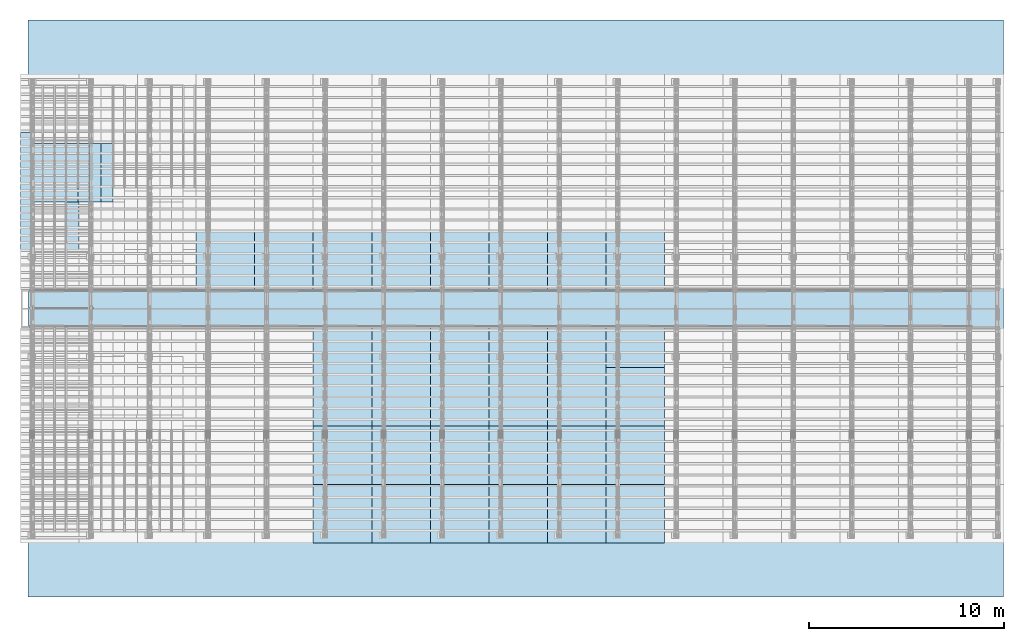
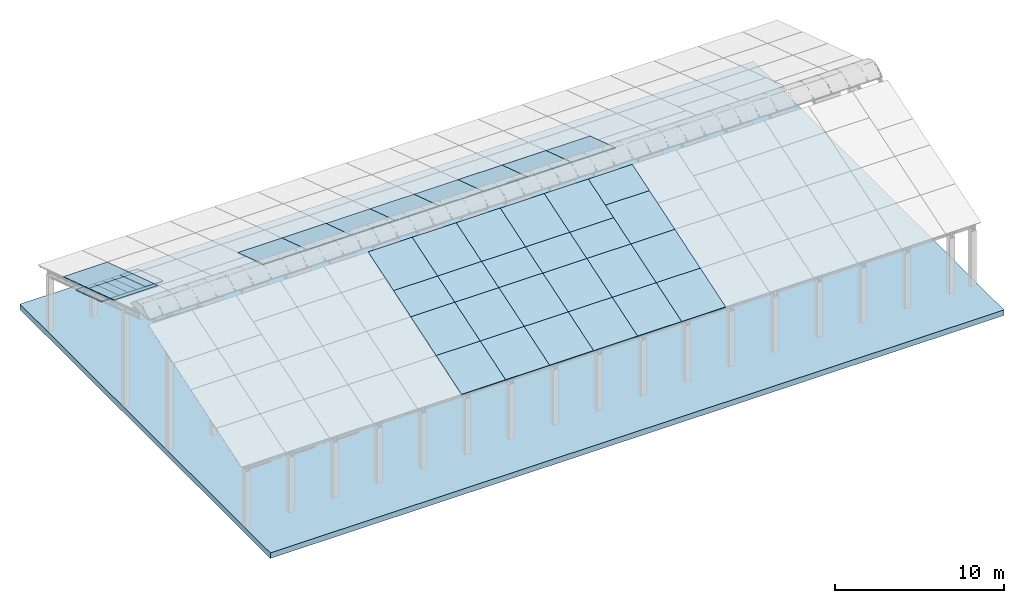
# One storey, part 7 of 385: 43 slabs, 42 elements without a shape of their own.
"""IFC2X3 building model written with IfcOpenShell, lengths in millimetres."""

from ifc_helpers import new_model, entity, si_unit, converted_unit, derived_unit, direction, frame, frame_2d, origin, place, context, subcontext, project, spatial, rectangle, extrude, material, layer, layer_set, type_object, element, aggregate, save


model = new_model("IFC2X3")

# Units and contexts
model_context = context("Model", 3, precision=0.01, world=origin(), true_north=direction((6.12303176911189e-17, 1.0)))
body_context = subcontext(model_context, "Body", "Model", "MODEL_VIEW")
ifc_project = project(units=[si_unit("LENGTHUNIT", "METRE", prefix="MILLI"), si_unit("AREAUNIT", "SQUARE_METRE"), si_unit("VOLUMEUNIT", "CUBIC_METRE"), converted_unit("PLANEANGLEUNIT", "DEGREE", entity("IfcRatioMeasure", 0.0174532925199433), si_unit("PLANEANGLEUNIT", "RADIAN"), dimensions=[0, 0, 0, 0, 0, 0, 0]), si_unit("MASSUNIT", "GRAM", prefix="KILO"), derived_unit("MASSDENSITYUNIT", [(si_unit("MASSUNIT", "GRAM", prefix="KILO"), 1), (si_unit("LENGTHUNIT", "METRE"), -3)]), si_unit("TIMEUNIT", "SECOND"), si_unit("FREQUENCYUNIT", "HERTZ"), si_unit("THERMODYNAMICTEMPERATUREUNIT", "DEGREE_CELSIUS"), derived_unit("THERMALTRANSMITTANCEUNIT", [(si_unit("MASSUNIT", "GRAM", prefix="KILO"), 1), (si_unit("THERMODYNAMICTEMPERATUREUNIT", "KELVIN"), -1), (si_unit("TIMEUNIT", "SECOND"), -3)]), derived_unit("VOLUMETRICFLOWRATEUNIT", [(si_unit("LENGTHUNIT", "METRE"), 3), (si_unit("TIMEUNIT", "SECOND"), -1)]), si_unit("ELECTRICCURRENTUNIT", "AMPERE"), si_unit("ELECTRICVOLTAGEUNIT", "VOLT"), si_unit("POWERUNIT", "WATT"), si_unit("FORCEUNIT", "NEWTON", prefix="KILO"), si_unit("ILLUMINANCEUNIT", "LUX"), si_unit("LUMINOUSFLUXUNIT", "LUMEN"), si_unit("LUMINOUSINTENSITYUNIT", "CANDELA"), derived_unit("USERDEFINED", [(si_unit("MASSUNIT", "GRAM", prefix="KILO"), -1), (si_unit("LENGTHUNIT", "METRE"), -2), (si_unit("TIMEUNIT", "SECOND"), 3), (si_unit("LUMINOUSFLUXUNIT", "LUMEN"), 1)]), derived_unit("LINEARVELOCITYUNIT", [(si_unit("LENGTHUNIT", "METRE"), 1), (si_unit("TIMEUNIT", "SECOND"), -1)]), si_unit("PRESSUREUNIT", "PASCAL"), derived_unit("USERDEFINED", [(si_unit("LENGTHUNIT", "METRE"), -2), (si_unit("MASSUNIT", "GRAM", prefix="KILO"), 1), (si_unit("TIMEUNIT", "SECOND"), -2)])], contexts=[model_context])

# Site, building, storey
site_placement = place(None, origin())
site = spatial("IfcSite", under=ifc_project, at=site_placement, CompositionType="ELEMENT")
building_placement = place(site_placement, origin())
building = spatial("IfcBuilding", under=site, at=building_placement, CompositionType="ELEMENT")
storey_placement = place(building_placement, origin())
storey = spatial("IfcBuildingStorey", under=building, at=storey_placement, Name="Default", CompositionType="ELEMENT", Elevation=0.0)

# Slab
ifc_material_1 = material(Name="IfcSurfaceStyle #136")
slab_type = type_object("IfcSlabType", Name="Floor 1", PredefinedType="FLOOR", material=ifc_material_1)
slab_1_placement = place(building_placement, origin())
element("IfcSlab", 1, at=slab_1_placement, inside=storey, type_object=slab_type, Name="Floor 1:Floor 1", ObjectType="Floor 1:Floor 1", PredefinedType="FLOOR", context=body_context, shape_type="SweptSolid", body=[
    extrude(rectangle(XDim=50000.0, YDim=29560.0, at=frame_2d((3.63797880709171e-12, 2.72848410531878e-12), x_axis=(1.0, 0.0))), frame((25055.7043482528, 14726.7615632183, -4400.0), z_axis=(0.0, 0.0, 1.0), x_axis=(-1.0, 0.0, 0.0)), (0.0, 0.0, 1.0), 399.999999999997),
])

# Roof, slab
roof_1_placement = place(storey_placement, frame((-325.490958783834, 20742.4435684862, 1569.65703643478)))
roof_1 = element("IfcRoof", 2, at=roof_1_placement, inside=storey, ShapeType="NOTDEFINED")
ifc_material_2 = material()
ifc_layer_1 = layer(ifc_material_2, 40.0)
ifc_layer_set_1 = layer_set([ifc_layer_1])
slab_2_placement = place(roof_1_placement, origin())
slab_2 = element("IfcSlab", 3, at=slab_2_placement, material=ifc_layer_set_1, PredefinedType="ROOF", context=body_context, shape_type="SweptSolid", body=[
    extrude(rectangle(XDim=3154.3866727148, YDim=2999.99999999999, at=frame_2d((-4.54747350886464e-13, 1.13686837721616e-13), x_axis=(0.0, 1.0))), frame((1500.0, 1500.0, 487.379544349359), z_axis=(0.0, 0.309016994374947, 0.951056516295154), x_axis=(1.0, 0.0, 0.0)), (0.0, -0.309016994374947, 0.951056516295154), 42.0584889695308),
])
aggregate(roof_1, [slab_2])

roof_2_placement = place(storey_placement, frame((-325.490958783839, 17742.4435684862, 2544.4161251335)))
roof_2 = element("IfcRoof", 4, at=roof_2_placement, inside=storey, ShapeType="NOTDEFINED")
slab_3_placement = place(roof_2_placement, origin())
slab_3 = element("IfcSlab", 5, at=slab_3_placement, material=ifc_layer_set_1, PredefinedType="ROOF", context=body_context, shape_type="SweptSolid", body=[
    extrude(rectangle(XDim=3154.3866727148, YDim=2999.99999999999, at=frame_2d((-1.02318153949454e-12, 1.13686837721616e-12), x_axis=(0.0, 1.0))), frame((1500.0, 1500.0, 487.379544349359), z_axis=(0.0, 0.309016994374947, 0.951056516295154), x_axis=(1.0, 0.0, 0.0)), (0.0, -0.309016994374947, 0.951056516295154), 42.0584889695308),
])
aggregate(roof_2, [slab_3])

roof_3_placement = place(building_placement, frame((210.0, 20167.6676853402, 788.261817465712)))
roof_3 = element("IfcRoof", 6, at=roof_3_placement, inside=storey, ShapeType="NOTDEFINED")
ifc_material_3 = material(Name="NLRS_n7_isolatie MegaPlus_Kingspan")
ifc_layer_2 = layer(ifc_material_3, 60.0)
ifc_layer_set_2 = layer_set([ifc_layer_2])
slab_4_placement = place(roof_3_placement, origin())
slab_4 = element("IfcSlab", 7, at=slab_4_placement, material=ifc_layer_set_2, PredefinedType="ROOF", context=body_context, shape_type="SweptSolid", body=[
    extrude(rectangle(XDim=600.0, YDim=3154.38667271481, at=frame_2d((0.0, 0.0), x_axis=(-1.0, 0.0))), frame((300.0, 1500.0, 487.379544349361), z_axis=(0.0, 0.309016994374947, 0.951056516295154), x_axis=(1.0, 0.0, 0.0)), (0.0, -0.309016994374947, 0.951056516295154), 63.087733454296),
])
aggregate(roof_3, [slab_4])

roof_4_placement = place(storey_placement, frame((810.0, 20167.6676853402, 788.261817465712)))
roof_4 = element("IfcRoof", 8, at=roof_4_placement, inside=storey, ShapeType="NOTDEFINED")
slab_5_placement = place(roof_4_placement, origin())
slab_5 = element("IfcSlab", 9, at=slab_5_placement, material=ifc_layer_set_2, PredefinedType="ROOF", context=body_context, shape_type="SweptSolid", body=[
    extrude(rectangle(XDim=600.0, YDim=3154.38667271481, at=frame_2d((0.0, 0.0), x_axis=(-1.0, 0.0))), frame((300.0, 1500.0, 487.379544349361), z_axis=(0.0, 0.309016994374947, 0.951056516295154), x_axis=(1.0, 0.0, 0.0)), (0.0, -0.309016994374947, 0.951056516295154), 63.087733454296),
])
aggregate(roof_4, [slab_5])

roof_5_placement = place(storey_placement, frame((1410.0, 20167.6676853402, 788.261817465712)))
roof_5 = element("IfcRoof", 10, at=roof_5_placement, inside=storey, ShapeType="NOTDEFINED")
slab_6_placement = place(roof_5_placement, origin())
slab_6 = element("IfcSlab", 11, at=slab_6_placement, material=ifc_layer_set_2, PredefinedType="ROOF", context=body_context, shape_type="SweptSolid", body=[
    extrude(rectangle(XDim=600.0, YDim=3154.38667271481, at=frame_2d((0.0, 0.0), x_axis=(-1.0, 0.0))), frame((300.0, 1500.0, 487.379544349361), z_axis=(0.0, 0.309016994374947, 0.951056516295154), x_axis=(1.0, 0.0, 0.0)), (0.0, -0.309016994374947, 0.951056516295154), 63.087733454296),
])
aggregate(roof_5, [slab_6])

roof_6_placement = place(storey_placement, frame((2010.0, 20167.6676853402, 788.261817465712)))
roof_6 = element("IfcRoof", 12, at=roof_6_placement, inside=storey, ShapeType="NOTDEFINED")
slab_7_placement = place(roof_6_placement, origin())
slab_7 = element("IfcSlab", 13, at=slab_7_placement, material=ifc_layer_set_2, PredefinedType="ROOF", context=body_context, shape_type="SweptSolid", body=[
    extrude(rectangle(XDim=600.0, YDim=3154.38667271481, at=frame_2d((0.0, 0.0), x_axis=(-1.0, 0.0))), frame((300.0, 1500.0, 487.379544349361), z_axis=(0.0, 0.309016994374947, 0.951056516295154), x_axis=(1.0, 0.0, 0.0)), (0.0, -0.309016994374947, 0.951056516295154), 63.087733454296),
])
aggregate(roof_6, [slab_7])

roof_7_placement = place(storey_placement, frame((2610.0, 20167.6676853402, 788.261817465712)))
roof_7 = element("IfcRoof", 14, at=roof_7_placement, inside=storey, ShapeType="NOTDEFINED")
slab_8_placement = place(roof_7_placement, origin())
slab_8 = element("IfcSlab", 15, at=slab_8_placement, material=ifc_layer_set_2, PredefinedType="ROOF", context=body_context, shape_type="SweptSolid", body=[
    extrude(rectangle(XDim=600.0, YDim=3154.38667271481, at=frame_2d((0.0, 0.0), x_axis=(-1.0, 0.0))), frame((300.0, 1500.0, 487.379544349361), z_axis=(0.0, 0.309016994374947, 0.951056516295154), x_axis=(1.0, 0.0, 0.0)), (0.0, -0.309016994374947, 0.951056516295154), 63.087733454296),
])
aggregate(roof_7, [slab_8])

roof_8_placement = place(storey_placement, frame((3210.0, 20167.6676853402, 788.261817465712)))
roof_8 = element("IfcRoof", 16, at=roof_8_placement, inside=storey, ShapeType="NOTDEFINED")
slab_9_placement = place(roof_8_placement, origin())
slab_9 = element("IfcSlab", 17, at=slab_9_placement, material=ifc_layer_set_2, PredefinedType="ROOF", context=body_context, shape_type="SweptSolid", body=[
    extrude(rectangle(XDim=600.0, YDim=3154.38667271481, at=frame_2d((0.0, 0.0), x_axis=(-1.0, 0.0))), frame((300.0, 1500.0, 487.379544349361), z_axis=(0.0, 0.309016994374947, 0.951056516295154), x_axis=(1.0, 0.0, 0.0)), (0.0, -0.309016994374947, 0.951056516295154), 63.087733454296),
])
aggregate(roof_8, [slab_9])

roof_9_placement = place(storey_placement, frame((3810.0, 20167.6676853402, 788.261817465712)))
roof_9 = element("IfcRoof", 18, at=roof_9_placement, inside=storey, ShapeType="NOTDEFINED")
slab_10_placement = place(roof_9_placement, origin())
slab_10 = element("IfcSlab", 19, at=slab_10_placement, material=ifc_layer_set_2, PredefinedType="ROOF", context=body_context, shape_type="SweptSolid", body=[
    extrude(rectangle(XDim=600.0, YDim=3154.38667271481, at=frame_2d((0.0, 0.0), x_axis=(-1.0, 0.0))), frame((300.0, 1500.0, 487.379544349361), z_axis=(0.0, 0.309016994374947, 0.951056516295154), x_axis=(1.0, 0.0, 0.0)), (0.0, -0.309016994374947, 0.951056516295154), 63.087733454296),
])
aggregate(roof_9, [slab_10])

roof_10_placement = place(storey_placement, frame((3210.0, 20167.6676853402, 788.261817465712)))
roof_10 = element("IfcRoof", 20, at=roof_10_placement, inside=storey, ShapeType="NOTDEFINED")
slab_11_placement = place(roof_10_placement, origin())
slab_11 = element("IfcSlab", 21, at=slab_11_placement, material=ifc_layer_set_2, PredefinedType="ROOF", context=body_context, shape_type="SweptSolid", body=[
    extrude(rectangle(XDim=600.0, YDim=3154.38667271481, at=frame_2d((0.0, 0.0), x_axis=(-1.0, 0.0))), frame((300.0, 1500.0, 487.379544349361), z_axis=(0.0, 0.309016994374947, 0.951056516295154), x_axis=(1.0, 0.0, 0.0)), (0.0, -0.309016994374947, 0.951056516295154), 63.087733454296),
])
aggregate(roof_10, [slab_11])

roof_11_placement = place(storey_placement, frame((8674.50904121613, 15713.9166481203, 3203.52447589904)))
roof_11 = element("IfcRoof", 22, at=roof_11_placement, inside=storey, ShapeType="NOTDEFINED")
slab_12_placement = place(roof_11_placement, origin())
slab_12 = element("IfcSlab", 23, at=slab_12_placement, material=ifc_layer_set_1, PredefinedType="ROOF", context=body_context, shape_type="SweptSolid", body=[
    extrude(rectangle(XDim=3154.3866727148, YDim=2999.99999999999, at=frame_2d((5.6843418860808e-13, 1.13686837721616e-12), x_axis=(0.0, 1.0))), frame((1500.0, 1500.0, 487.379544349359), z_axis=(0.0, 0.309016994374947, 0.951056516295154), x_axis=(1.0, 0.0, 0.0)), (0.0, -0.309016994374947, 0.951056516295154), 42.0584889695308),
])
aggregate(roof_11, [slab_12])

roof_12_placement = place(storey_placement, frame((11674.5090412161, 15713.9166481203, 3203.52447589904)))
roof_12 = element("IfcRoof", 24, at=roof_12_placement, inside=storey, ShapeType="NOTDEFINED")
slab_13_placement = place(roof_12_placement, origin())
slab_13 = element("IfcSlab", 25, at=slab_13_placement, material=ifc_layer_set_1, PredefinedType="ROOF", context=body_context, shape_type="SweptSolid", body=[
    extrude(rectangle(XDim=3154.3866727148, YDim=2999.99999999999, at=frame_2d((0.0, 1.13686837721616e-12), x_axis=(0.0, 1.0))), frame((1500.0, 1500.0, 487.379544349359), z_axis=(0.0, 0.309016994374947, 0.951056516295154), x_axis=(1.0, 0.0, 0.0)), (0.0, -0.309016994374947, 0.951056516295154), 42.0584889695308),
])
aggregate(roof_12, [slab_13])

roof_13_placement = place(storey_placement, frame((14674.5090412161, 2697.55668997139, 594.897947736069)))
roof_13 = element("IfcRoof", 26, at=roof_13_placement, inside=storey, ShapeType="NOTDEFINED")
slab_14_placement = place(roof_13_placement, origin())
slab_14 = element("IfcSlab", 27, at=slab_14_placement, material=ifc_layer_set_1, PredefinedType="ROOF", context=body_context, shape_type="SweptSolid", body=[
    extrude(rectangle(XDim=3154.3866727148, YDim=2999.99999999999, at=frame_2d((0.0, 5.6843418860808e-13), x_axis=(0.0, -1.0))), frame((1500.0, 1500.0, 487.379544349359), z_axis=(0.0, -0.309016994374947, 0.951056516295154), x_axis=(1.0, 0.0, 0.0)), (0.0, 0.309016994374947, 0.951056516295154), 42.0584889695306),
])
aggregate(roof_13, [slab_14])

roof_14_placement = place(storey_placement, frame((14674.5090412161, 5697.5566899714, 1569.65703643478)))
roof_14 = element("IfcRoof", 28, at=roof_14_placement, inside=storey, ShapeType="NOTDEFINED")
slab_15_placement = place(roof_14_placement, origin())
slab_15 = element("IfcSlab", 29, at=slab_15_placement, material=ifc_layer_set_1, PredefinedType="ROOF", context=body_context, shape_type="SweptSolid", body=[
    extrude(rectangle(XDim=3154.3866727148, YDim=2999.99999999999, at=frame_2d((0.0, 6.82121026329696e-13), x_axis=(0.0, -1.0))), frame((1500.0, 1500.0, 487.379544349359), z_axis=(0.0, -0.309016994374947, 0.951056516295154), x_axis=(1.0, 0.0, 0.0)), (0.0, 0.309016994374947, 0.951056516295154), 42.0584889695306),
])
aggregate(roof_14, [slab_15])

roof_15_placement = place(storey_placement, frame((14674.5090412161, 8697.5566899714, 2544.4161251335)))
roof_15 = element("IfcRoof", 30, at=roof_15_placement, inside=storey, ShapeType="NOTDEFINED")
slab_16_placement = place(roof_15_placement, origin())
slab_16 = element("IfcSlab", 31, at=slab_16_placement, material=ifc_layer_set_1, PredefinedType="ROOF", context=body_context, shape_type="SweptSolid", body=[
    extrude(rectangle(XDim=3154.38667271481, YDim=2999.99999999999, at=frame_2d((0.0, -5.6843418860808e-13), x_axis=(0.0, -1.0))), frame((1500.0, 1500.0, 487.379544349359), z_axis=(0.0, -0.309016994374947, 0.951056516295154), x_axis=(1.0, 0.0, 0.0)), (0.0, 0.309016994374947, 0.951056516295154), 42.0584889695308),
])
aggregate(roof_15, [slab_16])

roof_16_placement = place(storey_placement, frame((14674.5090412161, 15713.9166481203, 3203.52447589904)))
roof_16 = element("IfcRoof", 32, at=roof_16_placement, inside=storey, ShapeType="NOTDEFINED")
slab_17_placement = place(roof_16_placement, origin())
slab_17 = element("IfcSlab", 33, at=slab_17_placement, material=ifc_layer_set_1, PredefinedType="ROOF", context=body_context, shape_type="SweptSolid", body=[
    extrude(rectangle(XDim=3154.3866727148, YDim=2999.99999999999, at=frame_2d((0.0, 1.13686837721616e-12), x_axis=(0.0, 1.0))), frame((1500.0, 1500.0, 487.379544349359), z_axis=(0.0, 0.309016994374947, 0.951056516295154), x_axis=(1.0, 0.0, 0.0)), (0.0, -0.309016994374947, 0.951056516295154), 42.0584889695308),
])
aggregate(roof_16, [slab_17])

roof_17_placement = place(storey_placement, frame((14674.5090412161, 10724.9959924011, 3203.1710874096)))
roof_17 = element("IfcRoof", 34, at=roof_17_placement, inside=storey, ShapeType="NOTDEFINED")
slab_18_placement = place(roof_17_placement, origin())
slab_18 = element("IfcSlab", 35, at=slab_18_placement, material=ifc_layer_set_1, PredefinedType="ROOF", context=body_context, shape_type="SweptSolid", body=[
    extrude(rectangle(XDim=3154.3866727148, YDim=2999.99999999999, at=frame_2d((0.0, 0.0), x_axis=(0.0, -1.0))), frame((1500.0, 1500.0, 487.379544349359), z_axis=(0.0, -0.309016994374947, 0.951056516295154), x_axis=(1.0, 0.0, 0.0)), (0.0, 0.309016994374947, 0.951056516295154), 42.0584889695308),
])
aggregate(roof_17, [slab_18])

roof_18_placement = place(storey_placement, frame((17674.5090412161, 2697.55668997138, 594.897947736069)))
roof_18 = element("IfcRoof", 36, at=roof_18_placement, inside=storey, ShapeType="NOTDEFINED")
slab_19_placement = place(roof_18_placement, origin())
slab_19 = element("IfcSlab", 37, at=slab_19_placement, material=ifc_layer_set_1, PredefinedType="ROOF", context=body_context, shape_type="SweptSolid", body=[
    extrude(rectangle(XDim=3154.3866727148, YDim=2999.99999999999, at=frame_2d((0.0, 0.0), x_axis=(0.0, -1.0))), frame((1500.0, 1500.0, 487.379544349359), z_axis=(0.0, -0.309016994374947, 0.951056516295154), x_axis=(1.0, 0.0, 0.0)), (0.0, 0.309016994374947, 0.951056516295154), 42.0584889695306),
])
aggregate(roof_18, [slab_19])

roof_19_placement = place(storey_placement, frame((17674.5090412161, 5697.55668997139, 1569.65703643478)))
roof_19 = element("IfcRoof", 38, at=roof_19_placement, inside=storey, ShapeType="NOTDEFINED")
slab_20_placement = place(roof_19_placement, origin())
slab_20 = element("IfcSlab", 39, at=slab_20_placement, material=ifc_layer_set_1, PredefinedType="ROOF", context=body_context, shape_type="SweptSolid", body=[
    extrude(rectangle(XDim=3154.3866727148, YDim=2999.99999999999, at=frame_2d((0.0, 1.13686837721616e-13), x_axis=(0.0, -1.0))), frame((1500.0, 1500.0, 487.379544349359), z_axis=(0.0, -0.309016994374947, 0.951056516295154), x_axis=(1.0, 0.0, 0.0)), (0.0, 0.309016994374947, 0.951056516295154), 42.0584889695306),
])
aggregate(roof_19, [slab_20])

roof_20_placement = place(storey_placement, frame((17674.5090412161, 8697.5566899714, 2544.4161251335)))
roof_20 = element("IfcRoof", 40, at=roof_20_placement, inside=storey, ShapeType="NOTDEFINED")
slab_21_placement = place(roof_20_placement, origin())
slab_21 = element("IfcSlab", 41, at=slab_21_placement, material=ifc_layer_set_1, PredefinedType="ROOF", context=body_context, shape_type="SweptSolid", body=[
    extrude(rectangle(XDim=3154.38667271481, YDim=2999.99999999999, at=frame_2d((0.0, -1.25055521493778e-12), x_axis=(0.0, -1.0))), frame((1500.0, 1500.0, 487.37954434936), z_axis=(0.0, -0.309016994374947, 0.951056516295154), x_axis=(1.0, 0.0, 0.0)), (0.0, 0.309016994374947, 0.951056516295154), 42.0584889695303),
])
aggregate(roof_20, [slab_21])

roof_21_placement = place(storey_placement, frame((17674.5090412161, 15713.9166481203, 3203.52447589904)))
roof_21 = element("IfcRoof", 42, at=roof_21_placement, inside=storey, ShapeType="NOTDEFINED")
slab_22_placement = place(roof_21_placement, origin())
slab_22 = element("IfcSlab", 43, at=slab_22_placement, material=ifc_layer_set_1, PredefinedType="ROOF", context=body_context, shape_type="SweptSolid", body=[
    extrude(rectangle(XDim=3154.3866727148, YDim=2999.99999999999, at=frame_2d((0.0, 1.13686837721616e-12), x_axis=(0.0, 1.0))), frame((1500.0, 1500.0, 487.379544349359), z_axis=(0.0, 0.309016994374947, 0.951056516295154), x_axis=(1.0, 0.0, 0.0)), (0.0, -0.309016994374947, 0.951056516295154), 42.0584889695308),
])
aggregate(roof_21, [slab_22])

roof_22_placement = place(storey_placement, frame((17674.5090412161, 10724.9959924011, 3203.1710874096)))
roof_22 = element("IfcRoof", 44, at=roof_22_placement, inside=storey, ShapeType="NOTDEFINED")
slab_23_placement = place(roof_22_placement, origin())
slab_23 = element("IfcSlab", 45, at=slab_23_placement, material=ifc_layer_set_1, PredefinedType="ROOF", context=body_context, shape_type="SweptSolid", body=[
    extrude(rectangle(XDim=3154.3866727148, YDim=2999.99999999999, at=frame_2d((0.0, 0.0), x_axis=(0.0, -1.0))), frame((1500.0, 1500.0, 487.379544349359), z_axis=(0.0, -0.309016994374947, 0.951056516295154), x_axis=(1.0, 0.0, 0.0)), (0.0, 0.309016994374947, 0.951056516295154), 42.0584889695308),
])
aggregate(roof_22, [slab_23])

roof_23_placement = place(storey_placement, frame((20674.5090412161, 2697.55668997137, 594.897947736069)))
roof_23 = element("IfcRoof", 46, at=roof_23_placement, inside=storey, ShapeType="NOTDEFINED")
slab_24_placement = place(roof_23_placement, origin())
slab_24 = element("IfcSlab", 47, at=slab_24_placement, material=ifc_layer_set_1, PredefinedType="ROOF", context=body_context, shape_type="SweptSolid", body=[
    extrude(rectangle(XDim=3154.3866727148, YDim=2999.99999999999, at=frame_2d((0.0, 5.6843418860808e-13), x_axis=(0.0, -1.0))), frame((1500.0, 1500.0, 487.379544349359), z_axis=(0.0, -0.309016994374947, 0.951056516295154), x_axis=(1.0, 0.0, 0.0)), (0.0, 0.309016994374947, 0.951056516295154), 42.0584889695306),
])
aggregate(roof_23, [slab_24])

roof_24_placement = place(storey_placement, frame((20674.5090412161, 5697.55668997138, 1569.65703643478)))
roof_24 = element("IfcRoof", 48, at=roof_24_placement, inside=storey, ShapeType="NOTDEFINED")
slab_25_placement = place(roof_24_placement, origin())
slab_25 = element("IfcSlab", 49, at=slab_25_placement, material=ifc_layer_set_1, PredefinedType="ROOF", context=body_context, shape_type="SweptSolid", body=[
    extrude(rectangle(XDim=3154.3866727148, YDim=2999.99999999999, at=frame_2d((0.0, 6.82121026329696e-13), x_axis=(0.0, -1.0))), frame((1500.0, 1500.0, 487.379544349359), z_axis=(0.0, -0.309016994374947, 0.951056516295154), x_axis=(1.0, 0.0, 0.0)), (0.0, 0.309016994374947, 0.951056516295154), 42.0584889695306),
])
aggregate(roof_24, [slab_25])

roof_25_placement = place(storey_placement, frame((20674.5090412161, 8697.55668997138, 2544.4161251335)))
roof_25 = element("IfcRoof", 50, at=roof_25_placement, inside=storey, ShapeType="NOTDEFINED")
slab_26_placement = place(roof_25_placement, origin())
slab_26 = element("IfcSlab", 51, at=slab_26_placement, material=ifc_layer_set_1, PredefinedType="ROOF", context=body_context, shape_type="SweptSolid", body=[
    extrude(rectangle(XDim=3154.38667271481, YDim=2999.99999999999, at=frame_2d((0.0, 6.82121026329696e-13), x_axis=(0.0, -1.0))), frame((1500.0, 1500.0, 487.37954434936), z_axis=(0.0, -0.309016994374947, 0.951056516295154), x_axis=(1.0, 0.0, 0.0)), (0.0, 0.309016994374947, 0.951056516295154), 42.0584889695308),
])
aggregate(roof_25, [slab_26])

roof_26_placement = place(storey_placement, frame((20674.5090412161, 15713.9166481203, 3203.52447589904)))
roof_26 = element("IfcRoof", 52, at=roof_26_placement, inside=storey, ShapeType="NOTDEFINED")
slab_27_placement = place(roof_26_placement, origin())
slab_27 = element("IfcSlab", 53, at=slab_27_placement, material=ifc_layer_set_1, PredefinedType="ROOF", context=body_context, shape_type="SweptSolid", body=[
    extrude(rectangle(XDim=3154.3866727148, YDim=2999.99999999999, at=frame_2d((0.0, 1.13686837721616e-12), x_axis=(0.0, 1.0))), frame((1500.0, 1500.0, 487.379544349359), z_axis=(0.0, 0.309016994374947, 0.951056516295154), x_axis=(1.0, 0.0, 0.0)), (0.0, -0.309016994374947, 0.951056516295154), 42.0584889695308),
])
aggregate(roof_26, [slab_27])

roof_27_placement = place(storey_placement, frame((20674.5090412161, 10724.995992401, 3203.1710874096)))
roof_27 = element("IfcRoof", 54, at=roof_27_placement, inside=storey, ShapeType="NOTDEFINED")
slab_28_placement = place(roof_27_placement, origin())
slab_28 = element("IfcSlab", 55, at=slab_28_placement, material=ifc_layer_set_1, PredefinedType="ROOF", context=body_context, shape_type="SweptSolid", body=[
    extrude(rectangle(XDim=3154.3866727148, YDim=2999.99999999999, at=frame_2d((0.0, 0.0), x_axis=(0.0, -1.0))), frame((1500.0, 1500.0, 487.379544349359), z_axis=(0.0, -0.309016994374947, 0.951056516295154), x_axis=(1.0, 0.0, 0.0)), (0.0, 0.309016994374947, 0.951056516295154), 42.0584889695308),
])
aggregate(roof_27, [slab_28])

roof_28_placement = place(storey_placement, frame((23674.5090412161, 2697.55668997136, 594.897947736069)))
roof_28 = element("IfcRoof", 56, at=roof_28_placement, inside=storey, ShapeType="NOTDEFINED")
slab_29_placement = place(roof_28_placement, origin())
slab_29 = element("IfcSlab", 57, at=slab_29_placement, material=ifc_layer_set_1, PredefinedType="ROOF", context=body_context, shape_type="SweptSolid", body=[
    extrude(rectangle(XDim=3154.3866727148, YDim=2999.99999999999, at=frame_2d((0.0, 0.0), x_axis=(0.0, -1.0))), frame((1500.0, 1500.0, 487.379544349359), z_axis=(0.0, -0.309016994374947, 0.951056516295154), x_axis=(1.0, 0.0, 0.0)), (0.0, 0.309016994374947, 0.951056516295154), 42.0584889695306),
])
aggregate(roof_28, [slab_29])

roof_29_placement = place(storey_placement, frame((23674.5090412161, 5697.55668997137, 1569.65703643478)))
roof_29 = element("IfcRoof", 58, at=roof_29_placement, inside=storey, ShapeType="NOTDEFINED")
slab_30_placement = place(roof_29_placement, origin())
slab_30 = element("IfcSlab", 59, at=slab_30_placement, material=ifc_layer_set_1, PredefinedType="ROOF", context=body_context, shape_type="SweptSolid", body=[
    extrude(rectangle(XDim=3154.3866727148, YDim=2999.99999999999, at=frame_2d((0.0, 1.13686837721616e-13), x_axis=(0.0, -1.0))), frame((1500.0, 1500.0, 487.379544349359), z_axis=(0.0, -0.309016994374947, 0.951056516295154), x_axis=(1.0, 0.0, 0.0)), (0.0, 0.309016994374947, 0.951056516295154), 42.0584889695306),
])
aggregate(roof_29, [slab_30])

roof_30_placement = place(storey_placement, frame((23674.5090412161, 8697.55668997138, 2544.4161251335)))
roof_30 = element("IfcRoof", 60, at=roof_30_placement, inside=storey, ShapeType="NOTDEFINED")
slab_31_placement = place(roof_30_placement, origin())
slab_31 = element("IfcSlab", 61, at=slab_31_placement, material=ifc_layer_set_1, PredefinedType="ROOF", context=body_context, shape_type="SweptSolid", body=[
    extrude(rectangle(XDim=3154.38667271481, YDim=2999.99999999999, at=frame_2d((0.0, 0.0), x_axis=(0.0, -1.0))), frame((1500.0, 1500.0, 487.37954434936), z_axis=(0.0, -0.309016994374947, 0.951056516295154), x_axis=(1.0, 0.0, 0.0)), (0.0, 0.309016994374947, 0.951056516295154), 42.0584889695308),
])
aggregate(roof_30, [slab_31])

roof_31_placement = place(storey_placement, frame((23674.5090412161, 15713.9166481202, 3203.52447589904)))
roof_31 = element("IfcRoof", 62, at=roof_31_placement, inside=storey, ShapeType="NOTDEFINED")
slab_32_placement = place(roof_31_placement, origin())
slab_32 = element("IfcSlab", 63, at=slab_32_placement, material=ifc_layer_set_1, PredefinedType="ROOF", context=body_context, shape_type="SweptSolid", body=[
    extrude(rectangle(XDim=3154.3866727148, YDim=2999.99999999999, at=frame_2d((0.0, 1.13686837721616e-12), x_axis=(0.0, 1.0))), frame((1500.0, 1500.0, 487.379544349359), z_axis=(0.0, 0.309016994374947, 0.951056516295154), x_axis=(1.0, 0.0, 0.0)), (0.0, -0.309016994374947, 0.951056516295154), 42.0584889695308),
])
aggregate(roof_31, [slab_32])

roof_32_placement = place(storey_placement, frame((23674.5090412161, 10724.995992401, 3203.1710874096)))
roof_32 = element("IfcRoof", 64, at=roof_32_placement, inside=storey, ShapeType="NOTDEFINED")
slab_33_placement = place(roof_32_placement, origin())
slab_33 = element("IfcSlab", 65, at=slab_33_placement, material=ifc_layer_set_1, PredefinedType="ROOF", context=body_context, shape_type="SweptSolid", body=[
    extrude(rectangle(XDim=3154.3866727148, YDim=2999.99999999999, at=frame_2d((0.0, 0.0), x_axis=(0.0, -1.0))), frame((1500.0, 1500.0, 487.379544349359), z_axis=(0.0, -0.309016994374947, 0.951056516295154), x_axis=(1.0, 0.0, 0.0)), (0.0, 0.309016994374947, 0.951056516295154), 42.0584889695308),
])
aggregate(roof_32, [slab_33])

roof_33_placement = place(storey_placement, frame((26674.5090412161, 2697.55668997135, 594.897947736069)))
roof_33 = element("IfcRoof", 66, at=roof_33_placement, inside=storey, ShapeType="NOTDEFINED")
slab_34_placement = place(roof_33_placement, origin())
slab_34 = element("IfcSlab", 67, at=slab_34_placement, material=ifc_layer_set_1, PredefinedType="ROOF", context=body_context, shape_type="SweptSolid", body=[
    extrude(rectangle(XDim=3154.3866727148, YDim=2999.99999999999, at=frame_2d((0.0, 5.6843418860808e-13), x_axis=(0.0, -1.0))), frame((1500.0, 1500.0, 487.379544349359), z_axis=(0.0, -0.309016994374947, 0.951056516295154), x_axis=(1.0, 0.0, 0.0)), (0.0, 0.309016994374947, 0.951056516295154), 42.0584889695306),
])
aggregate(roof_33, [slab_34])

roof_34_placement = place(storey_placement, frame((26674.5090412161, 5697.55668997136, 1569.65703643478)))
roof_34 = element("IfcRoof", 68, at=roof_34_placement, inside=storey, ShapeType="NOTDEFINED")
slab_35_placement = place(roof_34_placement, origin())
slab_35 = element("IfcSlab", 69, at=slab_35_placement, material=ifc_layer_set_1, PredefinedType="ROOF", context=body_context, shape_type="SweptSolid", body=[
    extrude(rectangle(XDim=3154.3866727148, YDim=2999.99999999999, at=frame_2d((0.0, 6.82121026329696e-13), x_axis=(0.0, -1.0))), frame((1500.0, 1500.0, 487.379544349359), z_axis=(0.0, -0.309016994374947, 0.951056516295154), x_axis=(1.0, 0.0, 0.0)), (0.0, 0.309016994374947, 0.951056516295154), 42.0584889695306),
])
aggregate(roof_34, [slab_35])

roof_35_placement = place(storey_placement, frame((26674.5090412161, 8697.55668997136, 2544.4161251335)))
roof_35 = element("IfcRoof", 70, at=roof_35_placement, inside=storey, ShapeType="NOTDEFINED")
slab_36_placement = place(roof_35_placement, origin())
slab_36 = element("IfcSlab", 71, at=slab_36_placement, material=ifc_layer_set_1, PredefinedType="ROOF", context=body_context, shape_type="SweptSolid", body=[
    extrude(rectangle(XDim=3154.38667271481, YDim=2999.99999999999, at=frame_2d((0.0, -5.6843418860808e-13), x_axis=(0.0, -1.0))), frame((1500.0, 1500.0, 487.37954434936), z_axis=(0.0, -0.309016994374947, 0.951056516295154), x_axis=(1.0, 0.0, 0.0)), (0.0, 0.309016994374947, 0.951056516295154), 42.0584889695308),
])
aggregate(roof_35, [slab_36])

roof_36_placement = place(storey_placement, frame((26674.5090412161, 15713.9166481202, 3203.52447589904)))
roof_36 = element("IfcRoof", 72, at=roof_36_placement, inside=storey, ShapeType="NOTDEFINED")
slab_37_placement = place(roof_36_placement, origin())
slab_37 = element("IfcSlab", 73, at=slab_37_placement, material=ifc_layer_set_1, PredefinedType="ROOF", context=body_context, shape_type="SweptSolid", body=[
    extrude(rectangle(XDim=3154.3866727148, YDim=2999.99999999999, at=frame_2d((0.0, 1.13686837721616e-12), x_axis=(0.0, 1.0))), frame((1500.0, 1500.0, 487.379544349359), z_axis=(0.0, 0.309016994374947, 0.951056516295154), x_axis=(1.0, 0.0, 0.0)), (0.0, -0.309016994374947, 0.951056516295154), 42.0584889695308),
])
aggregate(roof_36, [slab_37])

roof_37_placement = place(storey_placement, frame((26674.5090412161, 10724.995992401, 3203.1710874096)))
roof_37 = element("IfcRoof", 74, at=roof_37_placement, inside=storey, ShapeType="NOTDEFINED")
slab_38_placement = place(roof_37_placement, origin())
slab_38 = element("IfcSlab", 75, at=slab_38_placement, material=ifc_layer_set_1, PredefinedType="ROOF", context=body_context, shape_type="SweptSolid", body=[
    extrude(rectangle(XDim=3154.3866727148, YDim=2999.99999999999, at=frame_2d((0.0, 0.0), x_axis=(0.0, -1.0))), frame((1500.0, 1500.0, 487.379544349359), z_axis=(0.0, -0.309016994374947, 0.951056516295154), x_axis=(1.0, 0.0, 0.0)), (0.0, 0.309016994374947, 0.951056516295154), 42.0584889695308),
])
aggregate(roof_37, [slab_38])

roof_38_placement = place(storey_placement, frame((29674.5090412161, 2697.55668997134, 594.897947736069)))
roof_38 = element("IfcRoof", 76, at=roof_38_placement, inside=storey, ShapeType="NOTDEFINED")
slab_39_placement = place(roof_38_placement, origin())
slab_39 = element("IfcSlab", 77, at=slab_39_placement, material=ifc_layer_set_1, PredefinedType="ROOF", context=body_context, shape_type="SweptSolid", body=[
    extrude(rectangle(XDim=3154.3866727148, YDim=2999.99999999999, at=frame_2d((0.0, 0.0), x_axis=(0.0, -1.0))), frame((1500.0, 1500.0, 487.379544349359), z_axis=(0.0, -0.309016994374947, 0.951056516295154), x_axis=(1.0, 0.0, 0.0)), (0.0, 0.309016994374947, 0.951056516295154), 42.0584889695306),
])
aggregate(roof_38, [slab_39])

roof_39_placement = place(storey_placement, frame((29674.5090412161, 5697.55668997135, 1569.65703643478)))
roof_39 = element("IfcRoof", 78, at=roof_39_placement, inside=storey, ShapeType="NOTDEFINED")
slab_40_placement = place(roof_39_placement, origin())
slab_40 = element("IfcSlab", 79, at=slab_40_placement, material=ifc_layer_set_1, PredefinedType="ROOF", context=body_context, shape_type="SweptSolid", body=[
    extrude(rectangle(XDim=3154.3866727148, YDim=2999.99999999999, at=frame_2d((0.0, 1.13686837721616e-13), x_axis=(0.0, -1.0))), frame((1500.0, 1500.0, 487.379544349359), z_axis=(0.0, -0.309016994374947, 0.951056516295154), x_axis=(1.0, 0.0, 0.0)), (0.0, 0.309016994374947, 0.951056516295154), 42.0584889695306),
])
aggregate(roof_39, [slab_40])

roof_40_placement = place(storey_placement, frame((29674.5090412161, 8697.55668997136, 2544.4161251335)))
roof_40 = element("IfcRoof", 80, at=roof_40_placement, inside=storey, ShapeType="NOTDEFINED")
slab_41_placement = place(roof_40_placement, origin())
slab_41 = element("IfcSlab", 81, at=slab_41_placement, material=ifc_layer_set_1, PredefinedType="ROOF", context=body_context, shape_type="SweptSolid", body=[
    extrude(rectangle(XDim=3154.38667271481, YDim=2999.99999999999, at=frame_2d((0.0, -9.09494701772928e-13), x_axis=(0.0, -1.0))), frame((1500.0, 1500.0, 487.37954434936), z_axis=(0.0, -0.309016994374947, 0.951056516295154), x_axis=(1.0, 0.0, 0.0)), (0.0, 0.309016994374947, 0.951056516295154), 42.0584889695308),
])
aggregate(roof_40, [slab_41])

roof_41_placement = place(storey_placement, frame((29674.5090412161, 15713.9166481202, 3203.52447589904)))
roof_41 = element("IfcRoof", 82, at=roof_41_placement, inside=storey, ShapeType="NOTDEFINED")
slab_42_placement = place(roof_41_placement, origin())
slab_42 = element("IfcSlab", 83, at=slab_42_placement, material=ifc_layer_set_1, PredefinedType="ROOF", context=body_context, shape_type="SweptSolid", body=[
    extrude(rectangle(XDim=3154.3866727148, YDim=2999.99999999999, at=frame_2d((0.0, 1.13686837721616e-12), x_axis=(0.0, 1.0))), frame((1500.0, 1500.0, 487.379544349359), z_axis=(0.0, 0.309016994374947, 0.951056516295154), x_axis=(1.0, 0.0, 0.0)), (0.0, -0.309016994374947, 0.951056516295154), 42.0584889695308),
])
aggregate(roof_41, [slab_42])

roof_42_placement = place(storey_placement, frame((29674.5090412161, 10724.995992401, 3203.1710874096)))
roof_42 = element("IfcRoof", 84, at=roof_42_placement, inside=storey, ShapeType="NOTDEFINED")
slab_43_placement = place(roof_42_placement, origin())
slab_43 = element("IfcSlab", 85, at=slab_43_placement, material=ifc_layer_set_1, PredefinedType="ROOF", context=body_context, shape_type="SweptSolid", body=[
    extrude(rectangle(XDim=3154.3866727148, YDim=2999.99999999999, at=frame_2d((0.0, 0.0), x_axis=(0.0, -1.0))), frame((1500.0, 1500.0, 487.379544349359), z_axis=(0.0, -0.309016994374947, 0.951056516295154), x_axis=(1.0, 0.0, 0.0)), (0.0, 0.309016994374947, 0.951056516295154), 42.0584889695308),
])
aggregate(roof_42, [slab_43])

save(model, "model.ifc")
